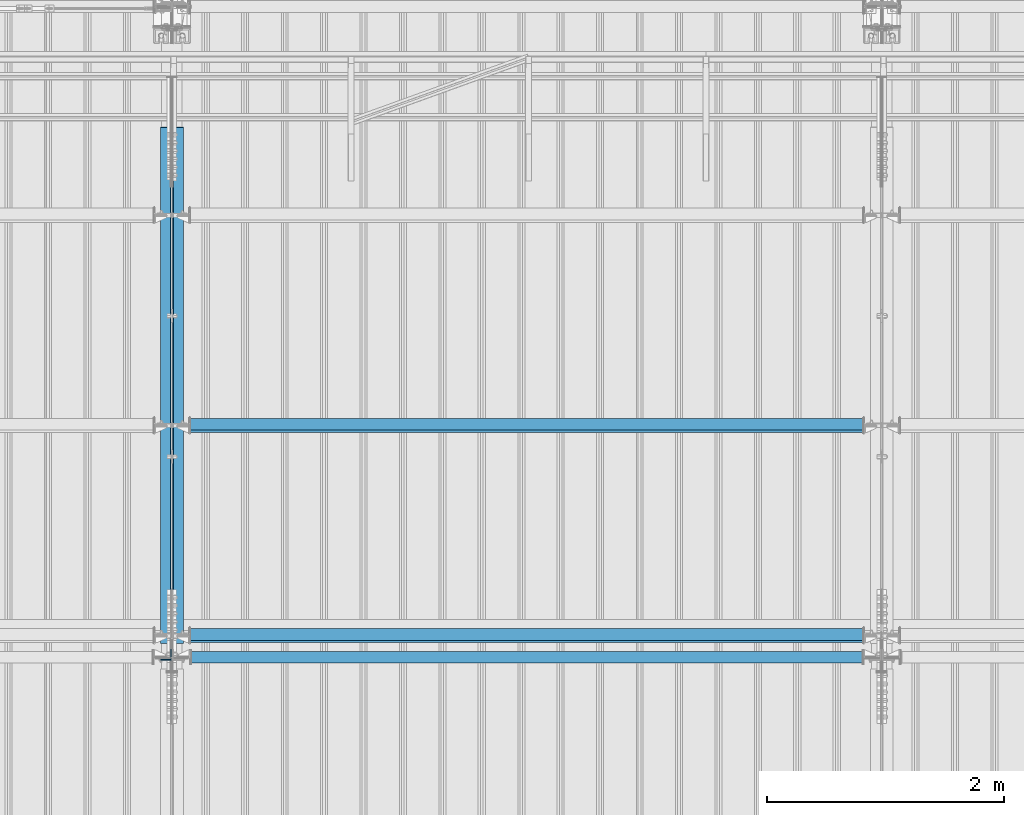
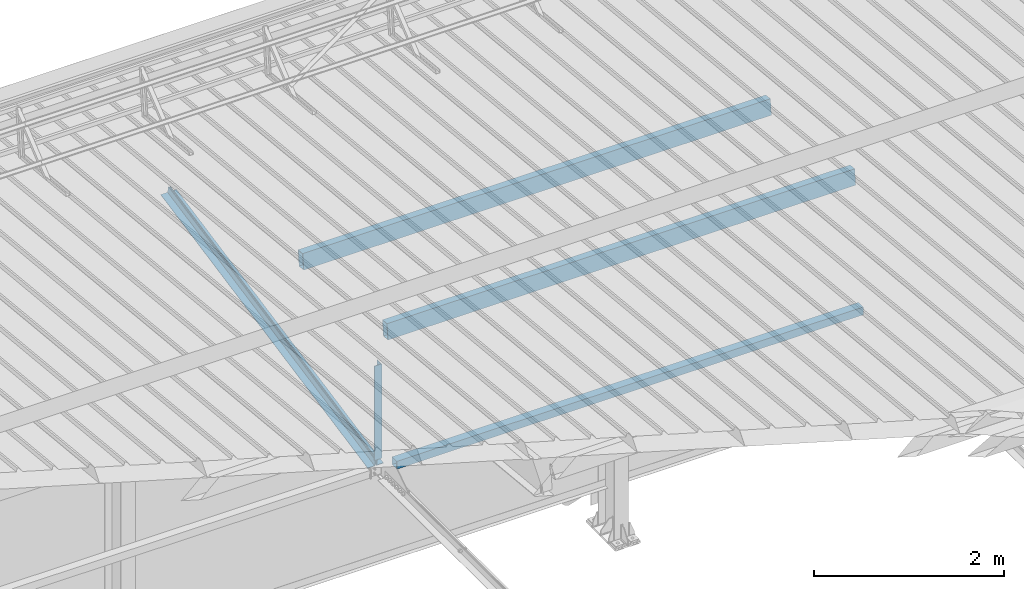
# One storey, part 269 of 709: 6 beams, 6 elements without a shape of their own.
"""IFC4 building model written with IfcOpenShell, lengths in millimetres."""

from ifc_helpers import new_model, si_unit, direction, frame, origin_with_axes, place, context, subcontext, project, spatial, polygons, material, element, aggregate, save


model = new_model("IFC4")

# Units and contexts
model_context = context("Model", 3, precision=0.2, world=origin_with_axes(), true_north=direction((0.0, 1.0)))
body_context = subcontext(model_context, "Body", "Model", "MODEL_VIEW")
ifc_project = project(units=[si_unit("LENGTHUNIT", "METRE", prefix="MILLI"), si_unit("AREAUNIT", "SQUARE_METRE"), si_unit("VOLUMEUNIT", "CUBIC_METRE"), si_unit("MASSUNIT", "GRAM", prefix="KILO"), si_unit("TIMEUNIT", "SECOND"), si_unit("PLANEANGLEUNIT", "RADIAN"), si_unit("SOLIDANGLEUNIT", "STERADIAN"), si_unit("THERMODYNAMICTEMPERATUREUNIT", "DEGREE_CELSIUS"), si_unit("LUMINOUSINTENSITYUNIT", "LUMEN")], contexts=[model_context])

# Site, building, storey
site_placement = place(None, origin_with_axes())
site = spatial("IfcSite", under=ifc_project, at=site_placement, CompositionType="ELEMENT")
building_placement = place(site_placement, origin_with_axes())
building = spatial("IfcBuilding", under=site, at=building_placement, Name="Undefined", CompositionType="ELEMENT")
storey_placement = place(building_placement, origin_with_axes())
storey = spatial("IfcBuildingStorey", under=building, at=storey_placement, Name="Undefined", CompositionType="ELEMENT", Elevation=0.0)

# Assembly, beam
assembly_1_placement = place(storey_placement, frame((28051.0, 21649.9404, 7109.99804), z_axis=(0.0, -0.1961161349, 0.9805806757), x_axis=(0.0, -0.9805806757, -0.1961161349)))
assembly_1 = element("IfcElementAssembly", 1, at=assembly_1_placement, inside=storey)
ifc_material_1 = material(Name="C345-5", Category="STEEL")
beam_1_placement = place(assembly_1_placement, origin_with_axes())
beam_1 = element("IfcBeam", 2, at=beam_1_placement, material=ifc_material_1, ObjectType="444", context=body_context, shape_type="Tessellation", body=[
    polygons([(868.11437, -45.0, -45.0), (868.11437, 45.0, -45.0), (5317.375, 45.0, -45.0), (5317.375, -45.0, -45.0), (868.11437, 45.0, -39.0), (5317.375, 45.0, -39.0), (868.11437, -39.0, -39.0), (5317.375, -39.0, -39.0), (868.11437, -39.0, 45.0), (5317.375, -39.0, 45.0), (868.11437, -45.0, 45.0), (5317.375, -45.0, 45.0)], [[[1, 2, 3, 4]], [[2, 5, 6, 3]], [[5, 7, 8, 6]], [[7, 9, 10, 8]], [[9, 11, 12, 10]], [[11, 1, 4, 12]], [[6, 8, 10, 12, 4, 3]], [[11, 9, 7, 5, 2, 1]]], closed=True),
])
aggregate(assembly_1, [beam_1])

assembly_2_placement = place(storey_placement, frame((27949.0, 16322.9404, 6044.59804), z_axis=(0.0, -0.1961161349, 0.9805806757), x_axis=(0.0, 0.9805806757, 0.1961161349)))
assembly_2 = element("IfcElementAssembly", 3, at=assembly_2_placement, inside=storey)
beam_2_placement = place(assembly_2_placement, origin_with_axes())
beam_2 = element("IfcBeam", 4, at=beam_2_placement, material=ifc_material_1, ObjectType="444", context=body_context, shape_type="Tessellation", body=[
    polygons([(115.12039, -45.0, -45.0), (115.12039, 45.0, -45.0), (4564.38102, 45.0, -45.0), (4564.38102, -45.0, -45.0), (115.12039, 45.0, -39.0), (4564.38102, 45.0, -39.0), (115.12039, -39.0, -39.0), (4564.38102, -39.0, -39.0), (115.12039, -39.0, 45.0), (4564.38102, -39.0, 45.0), (115.12039, -45.0, 45.0), (4564.38102, -45.0, 45.0)], [[[1, 2, 3, 4]], [[2, 5, 6, 3]], [[5, 7, 8, 6]], [[7, 9, 10, 8]], [[9, 11, 12, 10]], [[11, 1, 4, 12]], [[6, 8, 10, 12, 4, 3]], [[11, 9, 7, 5, 2, 1]]], closed=True),
])
aggregate(assembly_2, [beam_2])

assembly_3_placement = place(storey_placement, frame((27949.0, 16347.7, 7622.40002), z_axis=(0.0, 1.0, 0.0), x_axis=(0.0, 0.0, -1.0)))
assembly_3 = element("IfcElementAssembly", 5, at=assembly_3_placement, inside=storey)
beam_3_placement = place(assembly_3_placement, origin_with_axes())
beam_3 = element("IfcBeam", 6, at=beam_3_placement, material=ifc_material_1, ObjectType="436", context=body_context, shape_type="Tessellation", body=[
    polygons([(198.6891, -45.0, -45.0), (198.6891, 45.0, -45.0), (1412.4, 45.0, -45.0), (1412.4, -45.0, -45.0), (198.6891, 45.0, -39.0), (1412.4, 45.0, -39.0), (198.6891, -39.0, -39.0), (1412.4, -39.0, -39.0), (198.6891, -39.0, 45.0), (1412.4, -39.0, 45.0), (198.6891, -45.0, 45.0), (1412.4, -45.0, 45.0)], [[[1, 2, 3, 4]], [[2, 5, 6, 3]], [[5, 7, 8, 6]], [[7, 9, 10, 8]], [[9, 11, 12, 10]], [[11, 1, 4, 12]], [[6, 8, 10, 12, 4, 3]], [[11, 9, 7, 5, 2, 1]]], closed=True),
])
aggregate(assembly_3, [beam_3])

assembly_4_placement = place(storey_placement, frame((28000.0, 16327.0, 6074.30002), z_axis=(0.0, -1.0, 0.0), x_axis=(1.0, 0.0, 0.0)))
assembly_4 = element("IfcElementAssembly", 7, at=assembly_4_placement, inside=storey)
ifc_material_2 = material(Name="C355", Category="STEEL")
beam_4_placement = place(assembly_4_placement, origin_with_axes())
beam_4 = element("IfcBeam", 8, at=beam_4_placement, material=ifc_material_2, ObjectType="557", context=body_context, shape_type="Tessellation", body=[
    polygons([(162.0, -47.0, -47.0), (162.0, -47.0, 47.0), (5838.0, -47.0, 47.0), (5838.0, -47.0, -47.0), (162.0, 47.0, 47.0), (5838.0, 47.0, 47.0), (162.0, 47.0, -47.0), (5838.0, 47.0, -47.0), (162.0, -50.0, -50.0), (162.0, 50.0, -50.0), (5838.0, 50.0, -50.0), (5838.0, -50.0, -50.0), (162.0, 50.0, 50.0), (5838.0, 50.0, 50.0), (162.0, -50.0, 50.0), (5838.0, -50.0, 50.0)], [[[1, 2, 3, 4]], [[2, 5, 6, 3]], [[5, 7, 8, 6]], [[7, 1, 4, 8]], [[9, 10, 11, 12]], [[10, 13, 14, 11]], [[13, 15, 16, 14]], [[15, 9, 12, 16]], [[14, 16, 12, 11], [6, 8, 4, 3]], [[15, 13, 10, 9], [7, 5, 2, 1]]], closed=True),
])
aggregate(assembly_4, [beam_4])

assembly_5_placement = place(storey_placement, frame((34000.0, 16509.95037, 7677.46908), z_axis=(0.0, -0.9950371902, 0.099503719), x_axis=(-1.0, 0.0, 0.0)))
assembly_5 = element("IfcElementAssembly", 9, at=assembly_5_placement, inside=storey)
beam_5_placement = place(assembly_5_placement, origin_with_axes())
beam_5 = element("IfcBeam", 10, at=beam_5_placement, material=ifc_material_2, ObjectType="579", context=body_context, shape_type="Tessellation", body=[
    polygons([(155.0, -96.0, -46.0), (155.0, -96.0, 46.0), (5845.0, -96.0, 46.0), (5845.0, -96.0, -46.0), (155.0, 96.0, 46.0), (5845.0, 96.0, 46.0), (155.0, 96.0, -46.0), (5845.0, 96.0, -46.0), (155.0, -100.0, -50.0), (155.0, 100.0, -50.0), (5845.0, 100.0, -50.0), (5845.0, -100.0, -50.0), (155.0, 100.0, 50.0), (5845.0, 100.0, 50.0), (155.0, -100.0, 50.0), (5845.0, -100.0, 50.0)], [[[1, 2, 3, 4]], [[2, 5, 6, 3]], [[5, 7, 8, 6]], [[7, 1, 4, 8]], [[9, 10, 11, 12]], [[10, 13, 14, 11]], [[13, 15, 16, 14]], [[15, 9, 12, 16]], [[14, 16, 12, 11], [6, 8, 4, 3]], [[15, 13, 10, 9], [7, 5, 2, 1]]], closed=True),
])
aggregate(assembly_5, [beam_5])

assembly_6_placement = place(storey_placement, frame((34000.0, 18286.65012, 7499.7991), z_axis=(0.0, -0.9950371902, 0.099503719), x_axis=(-1.0, 0.0, 0.0)))
assembly_6 = element("IfcElementAssembly", 11, at=assembly_6_placement, inside=storey)
beam_6_placement = place(assembly_6_placement, origin_with_axes())
beam_6 = element("IfcBeam", 12, at=beam_6_placement, material=ifc_material_2, ObjectType="579", context=body_context, shape_type="Tessellation", body=[
    polygons([(155.0, -96.0, -46.0), (155.0, -96.0, 46.0), (5845.0, -96.0, 46.0), (5845.0, -96.0, -46.0), (155.0, 96.0, 46.0), (5845.0, 96.0, 46.0), (155.0, 96.0, -46.0), (5845.0, 96.0, -46.0), (155.0, -100.0, -50.0), (155.0, 100.0, -50.0), (5845.0, 100.0, -50.0), (5845.0, -100.0, -50.0), (155.0, 100.0, 50.0), (5845.0, 100.0, 50.0), (155.0, -100.0, 50.0), (5845.0, -100.0, 50.0)], [[[1, 2, 3, 4]], [[2, 5, 6, 3]], [[5, 7, 8, 6]], [[7, 1, 4, 8]], [[9, 10, 11, 12]], [[10, 13, 14, 11]], [[13, 15, 16, 14]], [[15, 9, 12, 16]], [[14, 16, 12, 11], [6, 8, 4, 3]], [[15, 13, 10, 9], [7, 5, 2, 1]]], closed=True),
])
aggregate(assembly_6, [beam_6])

save(model, "model.ifc")
